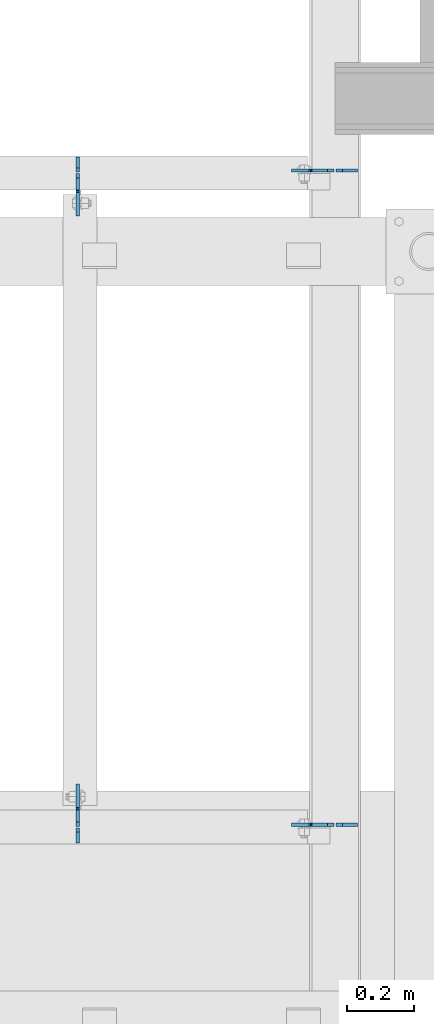
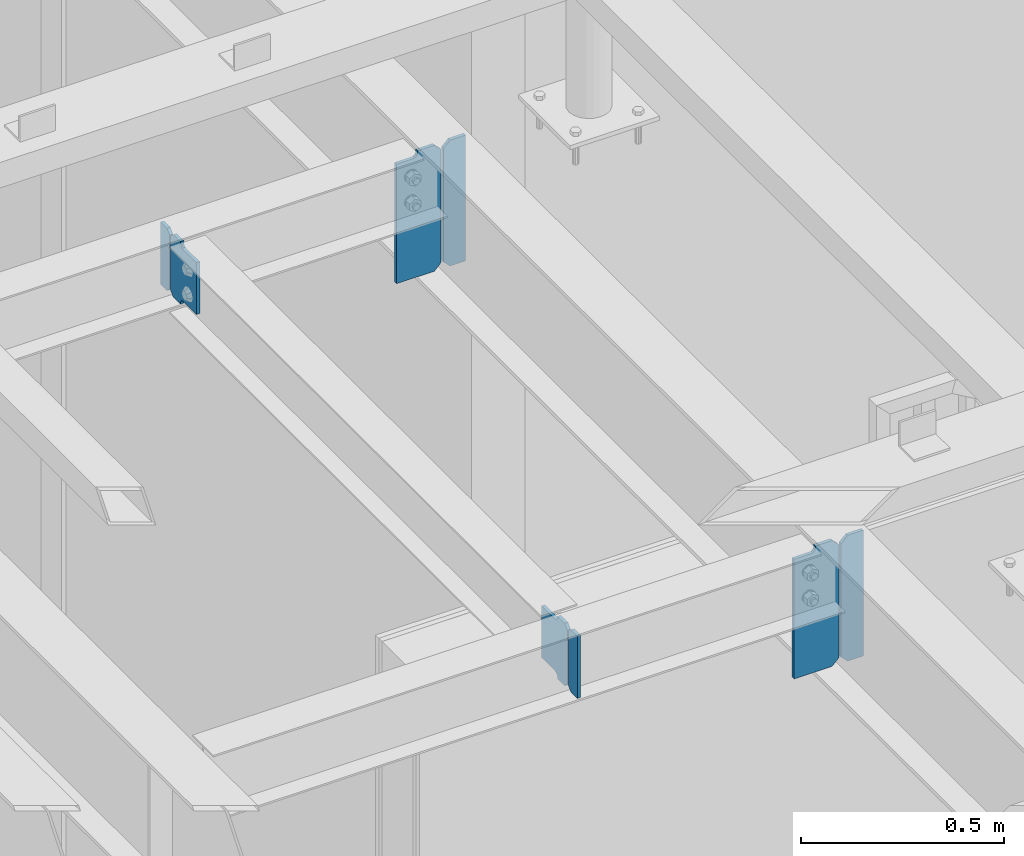
# One storey, part 1085 of 1179: 8 plates, 3 elements without a shape of their own.
"""IFC2X3 building model written with IfcOpenShell, lengths in millimetres."""

from ifc_helpers import new_model, si_unit, frame, origin_with_axes, place, context, subcontext, project, spatial, faceted_brep, material, type_object, element, aggregate, save


model = new_model("IFC2X3")

# Units and contexts
model_context = context("Model", 3, precision=1e-05, world=origin_with_axes())
body_context = subcontext(model_context, "Body", "Model", "MODEL_VIEW")
ifc_project = project(units=[si_unit("LENGTHUNIT", "METRE", prefix="MILLI"), si_unit("AREAUNIT", "SQUARE_METRE"), si_unit("VOLUMEUNIT", "CUBIC_METRE"), si_unit("MASSUNIT", "GRAM", prefix="KILO"), si_unit("TIMEUNIT", "SECOND"), si_unit("PLANEANGLEUNIT", "RADIAN"), si_unit("SOLIDANGLEUNIT", "STERADIAN"), si_unit("THERMODYNAMICTEMPERATUREUNIT", "DEGREE_CELSIUS"), si_unit("LUMINOUSINTENSITYUNIT", "LUMEN")], contexts=[model_context])

# Site, building, storey
site_placement = place(None, origin_with_axes())
site = spatial("IfcSite", under=ifc_project, at=site_placement, CompositionType="ELEMENT")
building_placement = place(site_placement, origin_with_axes())
building = spatial("IfcBuilding", under=site, at=building_placement, Name="Undefined", CompositionType="ELEMENT")
storey_placement = place(building_placement, origin_with_axes())
storey = spatial("IfcBuildingStorey", under=building, at=storey_placement, Name="Undefined", CompositionType="ELEMENT", Elevation=0.0)

# Assembly, plate
assembly_1_placement = place(storey_placement, origin_with_axes())
assembly_1 = element("IfcElementAssembly", 1, at=assembly_1_placement, inside=storey, Name="BEAM", AssemblyPlace="NOTDEFINED", PredefinedType="RIGID_FRAME")
ifc_material = material(Name="STEEL/A36")
plate_type_1 = type_object("IfcPlateType", PredefinedType="NOTDEFINED")
plate_1_placement = place(assembly_1_placement, frame((15690.0557500839, 35805.26875, 12925.425), z_axis=(0.0, 0.0, 1.0), x_axis=(0.0, -1.0, 0.0)))
plate_1 = element("IfcPlate", 2, at=plate_1_placement, type_object=plate_type_1, material=ifc_material, Name="PLATE", context=body_context, shape_type="Brep", body=[
    faceted_brep([(-2.72848410531878e-12, -4.76249999998981, 12.6999998092615), (0.0, -4.76250000000073, 174.624997138977), (0.0, 4.76250000000073, 174.624997138977), (-2.72848410531878e-12, 4.76250000000437, 12.699999809256), (12.6999998092651, -4.76250000000073, 187.324996948242), (12.6999998092651, 4.76250000000073, 187.324996948242), (44.4500007629395, -4.76250000000073, 187.324996948242), (44.4500007629395, 4.76250000000073, 187.324996948242), (44.4500000000007, -4.76250000000073, 0.0), (44.4500000000007, 4.76250000000073, 0.0), (12.6999998092651, -4.76249999999527, 1.81898940354586e-12), (12.6999998092651, 4.76250000000073, 0.0)], [[[0, 1, 2, 3]], [[1, 4, 5, 2]], [[4, 6, 7, 5]], [[6, 8, 9, 7]], [[8, 10, 11, 9]], [[10, 0, 3, 11]], [[5, 7, 9, 11, 3, 2]], [[10, 8, 6, 4, 1, 0]]]),
])

assembly_2_placement = place(storey_placement, origin_with_axes())
assembly_2 = element("IfcElementAssembly", 3, at=assembly_2_placement, inside=storey, Name="BEAM", AssemblyPlace="NOTDEFINED", PredefinedType="RIGID_FRAME")
plate_2_placement = place(assembly_2_placement, frame((15690.0557500839, 37765.83125, 12925.425), z_axis=(0.0, 0.0, 1.0), x_axis=(0.0, 1.0, 0.0)))
plate_2 = element("IfcPlate", 4, at=plate_2_placement, type_object=plate_type_1, material=ifc_material, Name="PLATE", context=body_context, shape_type="Brep", body=[
    faceted_brep([(-2.72848410531878e-12, -4.76249999998981, 12.6999998092615), (0.0, -4.76250000000073, 174.624997138977), (0.0, 4.76250000000073, 174.624997138977), (-2.72848410531878e-12, 4.76250000000437, 12.699999809256), (12.6999998092651, -4.76250000000073, 187.324996948242), (12.6999998092651, 4.76250000000073, 187.324996948242), (44.4500007629395, -4.76250000000073, 187.324996948242), (44.4500007629395, 4.76250000000073, 187.324996948242), (44.4500000000007, -4.76250000000073, 0.0), (44.4500000000007, 4.76250000000073, 0.0), (12.6999998092651, -4.76249999999527, 1.81898940354586e-12), (12.6999998092651, 4.76250000000073, 0.0)], [[[0, 1, 2, 3]], [[1, 4, 5, 2]], [[4, 6, 7, 5]], [[6, 8, 9, 7]], [[8, 10, 11, 9]], [[10, 0, 3, 11]], [[5, 7, 9, 11, 3, 2]], [[10, 8, 6, 4, 1, 0]]]),
])

# Plate
plate_type_2 = type_object("IfcPlateType", PredefinedType="NOTDEFINED")
plate_3_placement = place(assembly_1_placement, frame((15690.0557500839, 35810.03125, 12925.425), z_axis=(0.0, 0.0, 1.0), x_axis=(0.0, 1.0, 0.0)))
plate_3 = element("IfcPlate", 5, at=plate_3_placement, type_object=plate_type_2, material=ifc_material, Name="PLATE", context=body_context, shape_type="Brep", body=[
    faceted_brep([(48.4187500000044, -4.76250000000073, 187.325000000001), (48.4187500000044, -4.76250000000073, 184.15), (48.4187500000044, 4.76250000000073, 184.15), (48.4187500000044, 4.76250000000073, 187.325000000001), (49.3854799225956, -4.76250000000073, 179.289920291218), (49.3854799225956, 4.76250000000073, 179.289920291218), (52.1384938230694, -4.76250000000073, 175.169743823064), (52.1384938230694, 4.76250000000073, 175.169743823064), (56.2586702912231, -4.76250000000073, 172.416729922586), (56.2586702912231, 4.76250000000073, 172.416729922586), (61.1187498092695, -4.76250000000073, 171.449999999999), (61.1187498092695, 4.76250000000073, 171.449999999999), (127.0, -4.76250000000073, 171.449999999999), (127.0, 4.76250000000073, 171.449999999999), (0.0, -4.76250000000073, 174.624997138977), (12.6999998092651, -4.76250000000073, 187.324996948242), (12.6999998092651, 4.76250000000073, 187.324996948242), (0.0, 4.76250000000073, 174.624997138977), (-2.72848410531878e-12, -4.76249999998981, 12.6999998092615), (-2.72848410531878e-12, 4.76250000000437, 12.699999809256), (12.6999998092651, -4.76249999999527, 1.81898940354586e-12), (12.6999998092651, 4.76250000000073, 0.0), (48.4187500000044, 4.76250000000073, 0.0), (48.4187500000044, -4.76250000000073, 0.0), (48.4187500000044, 4.76250000000073, 3.17500019073668), (48.4187500000044, -4.76250000000073, 3.17500019073668), (49.3854799225956, 4.76250000000073, 8.03507970878309), (49.3854799225956, -4.76250000000073, 8.03507970878309), (52.1384938230694, 4.76250000000073, 12.1552561769367), (52.1384938230694, -4.76250000000073, 12.1552561769367), (56.2586702912231, 4.76250000000073, 14.9082700774143), (56.2586702912231, -4.76250000000073, 14.9082700774143), (61.1187498092695, 4.76250000000073, 15.8750000000018), (61.1187498092695, -4.76250000000073, 15.8750000000018), (127.000004117435, -4.76250000000073, 15.8749999995416), (127.000004116067, 4.76250000000073, 15.8749999995416)], [[[0, 1, 2, 3]], [[4, 5, 2, 1]], [[6, 7, 5, 4]], [[8, 9, 7, 6]], [[10, 11, 9, 8]], [[12, 13, 11, 10]], [[14, 15, 16, 17]], [[18, 14, 17, 19]], [[20, 18, 19, 21]], [[20, 21, 22, 23]], [[23, 22, 24, 25]], [[25, 24, 26, 27]], [[27, 26, 28, 29]], [[29, 28, 30, 31]], [[31, 30, 32, 33]], [[34, 33, 32, 35]], [[8, 6, 4, 1, 0, 15, 14, 18, 20, 23, 25, 27, 29, 31, 33, 34, 12, 10]], [[16, 15, 0, 3]], [[35, 32, 30, 28, 26, 24, 22, 21, 19, 17, 16, 3, 2, 5, 7, 9, 11, 13]], [[34, 35, 13, 12]]]),
])

aggregate(assembly_1, [plate_1, plate_3])

plate_4_placement = place(assembly_2_placement, frame((15690.0557500839, 37761.06875, 12925.425), z_axis=(0.0, 0.0, 1.0), x_axis=(0.0, -1.0, 0.0)))
plate_4 = element("IfcPlate", 6, at=plate_4_placement, type_object=plate_type_2, material=ifc_material, Name="PLATE", context=body_context, shape_type="Brep", body=[
    faceted_brep([(48.4187500000044, -4.76250000000073, 187.325000000001), (48.4187500000044, -4.76250000000073, 184.15), (48.4187500000044, 4.76250000000073, 184.15), (48.4187500000044, 4.76250000000073, 187.325000000001), (49.3854799225956, -4.76250000000073, 179.289920291218), (49.3854799225956, 4.76250000000073, 179.289920291218), (52.1384938230694, -4.76250000000073, 175.169743823064), (52.1384938230694, 4.76250000000073, 175.169743823064), (56.2586702912231, -4.76250000000073, 172.416729922586), (56.2586702912231, 4.76250000000073, 172.416729922586), (61.1187498092695, -4.76250000000073, 171.449999999999), (61.1187498092695, 4.76250000000073, 171.449999999999), (127.0, -4.76250000000073, 171.449999999999), (127.0, 4.76250000000073, 171.449999999999), (0.0, -4.76250000000073, 174.624997138977), (12.6999998092651, -4.76250000000073, 187.324996948242), (12.6999998092651, 4.76250000000073, 187.324996948242), (0.0, 4.76250000000073, 174.624997138977), (-2.72848410531878e-12, -4.76249999998981, 12.6999998092615), (-2.72848410531878e-12, 4.76250000000437, 12.699999809256), (12.6999998092651, -4.76249999999527, 1.81898940354586e-12), (12.6999998092651, 4.76250000000073, 0.0), (48.4187500000044, 4.76250000000073, 0.0), (48.4187500000044, -4.76250000000073, 0.0), (48.4187500000044, 4.76250000000073, 3.17500019073668), (48.4187500000044, -4.76250000000073, 3.17500019073668), (49.3854799225956, 4.76250000000073, 8.03507970878309), (49.3854799225956, -4.76250000000073, 8.03507970878309), (52.1384938230694, 4.76250000000073, 12.1552561769367), (52.1384938230694, -4.76250000000073, 12.1552561769367), (56.2586702912231, 4.76250000000073, 14.9082700774143), (56.2586702912231, -4.76250000000073, 14.9082700774143), (61.1187498092695, 4.76250000000073, 15.8750000000018), (61.1187498092695, -4.76250000000073, 15.8750000000018), (127.000004117435, -4.76250000000073, 15.8749999995416), (127.000004116067, 4.76250000000073, 15.8749999995416)], [[[0, 1, 2, 3]], [[4, 5, 2, 1]], [[6, 7, 5, 4]], [[8, 9, 7, 6]], [[10, 11, 9, 8]], [[12, 13, 11, 10]], [[14, 15, 16, 17]], [[18, 14, 17, 19]], [[20, 18, 19, 21]], [[20, 21, 22, 23]], [[23, 22, 24, 25]], [[25, 24, 26, 27]], [[27, 26, 28, 29]], [[29, 28, 30, 31]], [[31, 30, 32, 33]], [[34, 33, 32, 35]], [[8, 6, 4, 1, 0, 15, 14, 18, 20, 23, 25, 27, 29, 31, 33, 34, 12, 10]], [[16, 15, 0, 3]], [[35, 32, 30, 28, 26, 24, 22, 21, 19, 17, 16, 3, 2, 5, 7, 9, 11, 13]], [[34, 35, 13, 12]]]),
])

aggregate(assembly_2, [plate_2, plate_4])

# Assembly, plates
assembly_3_placement = place(storey_placement, origin_with_axes())
assembly_3 = element("IfcElementAssembly", 7, at=assembly_3_placement, inside=storey, Name="BEAM", AssemblyPlace="NOTDEFINED", PredefinedType="RIGID_FRAME")
plate_5_placement = place(assembly_3_placement, frame((16456.025, 35814.7942499161, 12728.575), z_axis=(0.0, 0.0, 1.0), x_axis=(-1.0, 0.0, 0.0)))
plate_5 = element("IfcPlate", 8, at=plate_5_placement, type_object=plate_type_2, material=ifc_material, Name="PLATE", context=body_context, shape_type="Brep", body=[
    faceted_brep([(66.6749998164378, -4.76249999999709, 377.825), (66.6749999434469, -4.76249999999709, 371.474999553748), (66.6749999434469, 4.76249999999709, 371.474999553748), (66.6749998164378, 4.76249999999709, 377.825), (67.641729938794, -4.76249999999709, 366.614920114053), (67.641729938794, 4.76249999999709, 366.614920114053), (70.394743855788, -4.76249999999709, 362.494743732281), (70.394743855788, 4.76249999999709, 362.494743732281), (74.5149202922948, -4.76249999999709, 359.741729897201), (74.5149202922948, 4.76249999999709, 359.741729897201), (79.3749997512095, -4.76249999999709, 358.774999998475), (79.3749997512095, 4.76249999999709, 358.774999998475), (127.000000004868, -4.76249999999709, 358.774999992755), (127.0, 4.76249999999709, 358.774999992755), (0.0, -4.76249999999709, 358.775000762939), (19.0499992370605, -4.76249999999709, 377.825), (19.0499992370605, 4.76249999999709, 377.825), (0.0, 4.76249999999709, 358.775000762939), (0.0, -4.76250000000073, 19.0499992370605), (0.0, 4.76250000000073, 19.0499992370605), (19.0499992370605, -4.76250000000073, 0.0), (19.0499992370605, 4.76250000000073, 0.0), (127.0, -4.76250000000073, 0.0), (127.0, 4.76250000000073, 0.0)], [[[0, 1, 2, 3]], [[4, 5, 2, 1]], [[6, 7, 5, 4]], [[8, 9, 7, 6]], [[10, 11, 9, 8]], [[12, 13, 11, 10]], [[14, 15, 16, 17]], [[18, 14, 17, 19]], [[20, 18, 19, 21]], [[22, 20, 21, 23]], [[8, 6, 4, 1, 0, 15, 14, 18, 20, 22, 12, 10]], [[16, 15, 0, 3]], [[23, 21, 19, 17, 16, 3, 2, 5, 7, 9, 11, 13]], [[22, 23, 13, 12]]]),
])
plate_6_placement = place(assembly_3_placement, frame((16456.025, 37770.5943683147, 12728.575), z_axis=(0.0, 0.0, 1.0), x_axis=(-1.0, 0.0, 0.0)))
plate_6 = element("IfcPlate", 9, at=plate_6_placement, type_object=plate_type_2, material=ifc_material, Name="PLATE", context=body_context, shape_type="Brep", body=[
    faceted_brep([(66.6749998164378, -4.76249999999709, 377.825), (66.6749999434469, -4.76249999999709, 371.474999553748), (66.6749999434469, 4.76249999999709, 371.474999553748), (66.6749998164378, 4.76249999999709, 377.825), (67.641729938794, -4.76249999999709, 366.614920114053), (67.641729938794, 4.76249999999709, 366.614920114053), (70.394743855788, -4.76249999999709, 362.494743732281), (70.394743855788, 4.76249999999709, 362.494743732281), (74.5149202922948, -4.76249999999709, 359.741729897201), (74.5149202922948, 4.76249999999709, 359.741729897201), (79.3749997512095, -4.76249999999709, 358.774999998475), (79.3749997512095, 4.76249999999709, 358.774999998475), (127.000000004868, -4.76249999999709, 358.774999992755), (127.0, 4.76249999999709, 358.774999992755), (0.0, -4.76249999999709, 358.775000762939), (19.0499992370605, -4.76249999999709, 377.825), (19.0499992370605, 4.76249999999709, 377.825), (0.0, 4.76249999999709, 358.775000762939), (0.0, -4.76250000000073, 19.0499992370605), (0.0, 4.76250000000073, 19.0499992370605), (19.0499992370605, -4.76250000000073, 0.0), (19.0499992370605, 4.76250000000073, 0.0), (127.0, -4.76250000000073, 0.0), (127.0, 4.76250000000073, 0.0)], [[[0, 1, 2, 3]], [[4, 5, 2, 1]], [[6, 7, 5, 4]], [[8, 9, 7, 6]], [[10, 11, 9, 8]], [[12, 13, 11, 10]], [[14, 15, 16, 17]], [[18, 14, 17, 19]], [[20, 18, 19, 21]], [[22, 20, 21, 23]], [[8, 6, 4, 1, 0, 15, 14, 18, 20, 22, 12, 10]], [[16, 15, 0, 3]], [[23, 21, 19, 17, 16, 3, 2, 5, 7, 9, 11, 13]], [[22, 23, 13, 12]]]),
])
plate_type_3 = type_object("IfcPlateType", PredefinedType="NOTDEFINED")
plate_7_placement = place(assembly_3_placement, frame((16462.375, 35814.7942499161, 12728.575), z_axis=(0.0, 0.0, 1.0), x_axis=(1.0, 0.0, 0.0)))
plate_7 = element("IfcPlate", 10, at=plate_7_placement, type_object=plate_type_3, material=ifc_material, Name="PLATE", context=body_context, shape_type="Brep", body=[
    faceted_brep([(0.0, -4.76250000000073, 19.0499992370605), (0.0, -4.76249999999709, 358.775000762939), (0.0, 4.76249999999709, 358.775000762939), (0.0, 4.76250000000073, 19.0499992370605), (19.0499992370605, -4.76249999999709, 377.825), (19.0499992370605, 4.76249999999709, 377.825), (63.5, -4.76250000000073, 377.825012207031), (63.5, 4.76250000000073, 377.825012207031), (63.5, -4.76250000000073, 0.0), (63.5, 4.76250000000073, 0.0), (19.0499992370605, -4.76250000000073, 0.0), (19.0499992370605, 4.76250000000073, 0.0)], [[[0, 1, 2, 3]], [[1, 4, 5, 2]], [[4, 6, 7, 5]], [[6, 8, 9, 7]], [[8, 10, 11, 9]], [[10, 0, 3, 11]], [[5, 7, 9, 11, 3, 2]], [[10, 8, 6, 4, 1, 0]]]),
])
plate_8_placement = place(assembly_3_placement, frame((16462.375, 37770.5943683147, 12728.575), z_axis=(0.0, 0.0, 1.0), x_axis=(1.0, 0.0, 0.0)))
plate_8 = element("IfcPlate", 11, at=plate_8_placement, type_object=plate_type_3, material=ifc_material, Name="PLATE", context=body_context, shape_type="Brep", body=[
    faceted_brep([(0.0, -4.76250000000073, 19.0499992370605), (0.0, -4.76249999999709, 358.775000762939), (0.0, 4.76249999999709, 358.775000762939), (0.0, 4.76250000000073, 19.0499992370605), (19.0499992370605, -4.76249999999709, 377.825), (19.0499992370605, 4.76249999999709, 377.825), (63.5, -4.76250000000073, 377.825012207031), (63.5, 4.76250000000073, 377.825012207031), (63.5, -4.76250000000073, 0.0), (63.5, 4.76250000000073, 0.0), (19.0499992370605, -4.76250000000073, 0.0), (19.0499992370605, 4.76250000000073, 0.0)], [[[0, 1, 2, 3]], [[1, 4, 5, 2]], [[4, 6, 7, 5]], [[6, 8, 9, 7]], [[8, 10, 11, 9]], [[10, 0, 3, 11]], [[5, 7, 9, 11, 3, 2]], [[10, 8, 6, 4, 1, 0]]]),
])
aggregate(assembly_3, [plate_7, plate_5, plate_8, plate_6])

save(model, "model.ifc")
